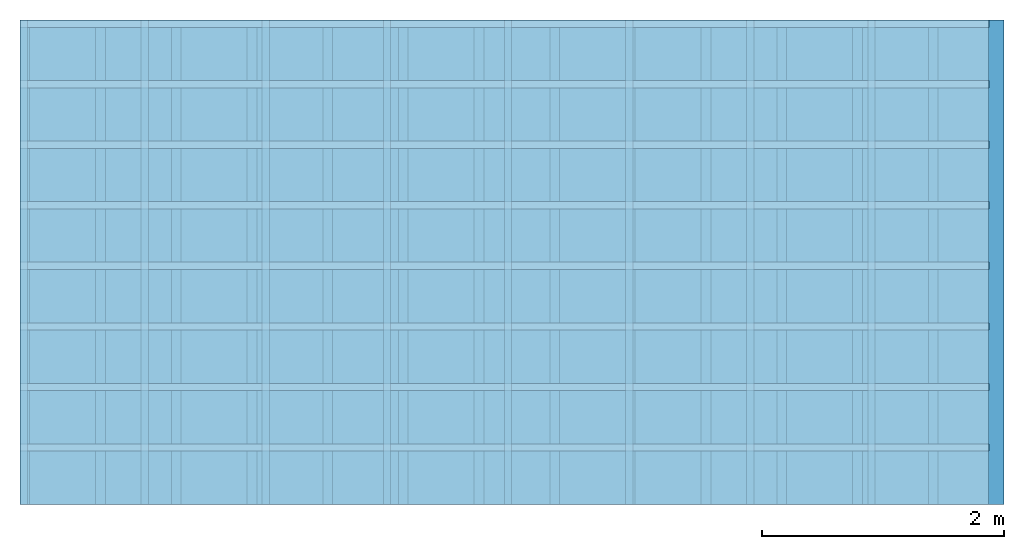
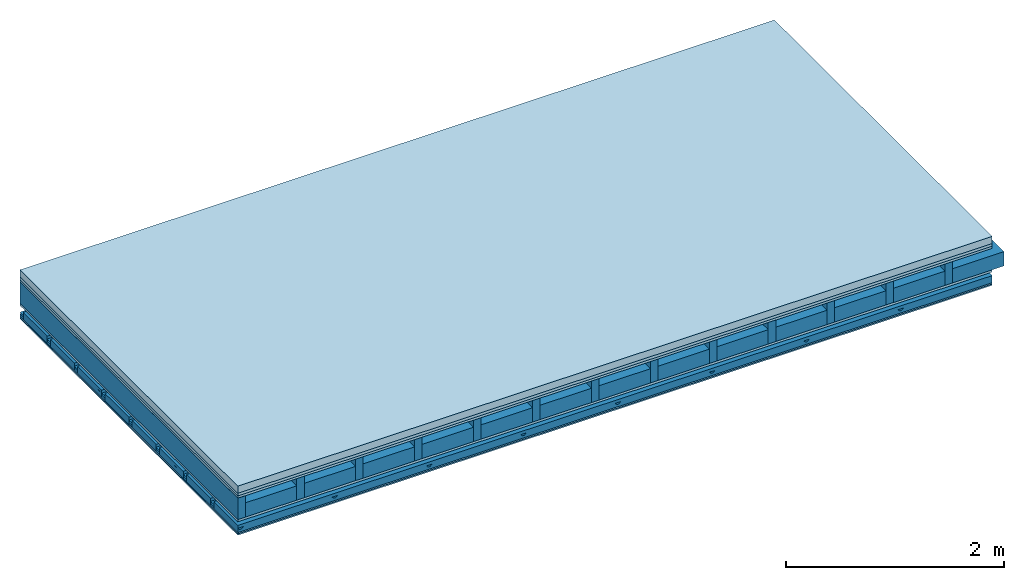
# One storey: 6 plates, 5 members, 1 element without a shape of its own.
"""IFC4 building model written with IfcOpenShell, lengths in metres."""

import ifcopenshell
import ifcopenshell.guid

model = None  # the IFC model being written
_history = None  # IfcOwnerHistory: only IFC2X3 demands one
_inside = {}  # id of a spatial element -> (the spatial element, [elements in it])
_under = {}  # id of a project, library or spatial element -> (it, [spatial elements below it])
_declared = {}  # id of a project -> (the project, [libraries it declares])
_typed = {}  # id of a type object -> (the type object, [elements of that type])
_made_of = {}  # id of a material, layer set ... -> (it, [elements and type objects made of it])


def new_model(schema):
    """Start an empty IFC model of exactly this schema.

    Asked for "IFC4X3", IfcOpenShell would pick the latest addendum, in which some entities
    have other attributes; the version numbers below select the first issue.
    IFC2X3 requires an IfcOwnerHistory on every rooted entity: one is made here for all.
    """
    global model, _history
    if schema == "IFC4X3":
        model = ifcopenshell.file(schema_version=(4, 3, 0, 0))
    else:
        model = ifcopenshell.file(schema=schema)
    _inside.clear()
    _under.clear()
    _declared.clear()
    _typed.clear()
    _made_of.clear()
    _history = None
    if model.schema == "IFC2X3":
        org = make("IfcOrganization", Name="unknown")
        user = make(
            "IfcPersonAndOrganization",
            ThePerson=make("IfcPerson", FamilyName="unknown"),
            TheOrganization=org,
        )
        app = make(
            "IfcApplication",
            ApplicationDeveloper=org,
            Version="unknown",
            ApplicationFullName="unknown",
            ApplicationIdentifier="unknown",
        )
        _history = make(
            "IfcOwnerHistory",
            OwningUser=user,
            OwningApplication=app,
            ChangeAction="ADDED",
            CreationDate=0,
        )
    return model


def make(cls, **values):
    """One entity of the class cls with the attributes given. An attribute that is None is left unset."""
    return model.create_entity(
        cls, **{name: value for name, value in values.items() if value is not None}
    )


def rooted(cls, **values):
    """An entity with a GlobalId (a new one), such as an element, a storey or a relation."""
    return make(cls, GlobalId=ifcopenshell.guid.new(), OwnerHistory=_history, **values)


def si_unit(unit_type, name, prefix=None):
    """IfcSIUnit, for example si_unit("LENGTHUNIT", "METRE", prefix="MILLI")."""
    return make("IfcSIUnit", UnitType=unit_type, Prefix=prefix, Name=name)


def derived_unit(unit_type, elements):
    """IfcDerivedUnit: a product of units, each with its exponent."""
    return make(
        "IfcDerivedUnit",
        Elements=[
            make("IfcDerivedUnitElement", Unit=unit, Exponent=power)
            for unit, power in elements
        ],
        UnitType=unit_type,
    )


def assignment(units):
    """IfcUnitAssignment: the units of a project."""
    return None if units is None else make("IfcUnitAssignment", Units=units)


def point(xyz):
    """IfcCartesianPoint."""
    return None if xyz is None else make("IfcCartesianPoint", Coordinates=xyz)


def direction(xyz):
    """IfcDirection."""
    return None if xyz is None else make("IfcDirection", DirectionRatios=xyz)


def frame(location, z_axis=None, x_axis=None):
    """IfcAxis2Placement3D, a coordinate frame: its origin and axes. An axis left out is left unset."""
    return make(
        "IfcAxis2Placement3D",
        Location=point(location),
        Axis=direction(z_axis),
        RefDirection=direction(x_axis),
    )


def frame_2d(location, x_axis=None):
    """IfcAxis2Placement2D, a coordinate frame in the plane: its origin and x axis."""
    return make(
        "IfcAxis2Placement2D", Location=point(location), RefDirection=direction(x_axis)
    )


def origin():
    """The frame at (0, 0, 0) with its axes left unset."""
    return frame((0.0, 0.0, 0.0))


def origin_with_axes():
    """The frame at (0, 0, 0) with the z axis (0, 0, 1) and the x axis (1, 0, 0) written out."""
    return frame((0.0, 0.0, 0.0), z_axis=(0.0, 0.0, 1.0), x_axis=(1.0, 0.0, 0.0))


def place(relative_to, where):
    """IfcLocalPlacement: puts the frame where relative to a parent placement (None: the world)."""
    return make(
        "IfcLocalPlacement", PlacementRelTo=relative_to, RelativePlacement=where
    )


def context(
    kind, dimensions, precision=None, world=None, true_north=None, identifier=None
):
    """IfcGeometricRepresentationContext, for example the 3D "Model" context."""
    return make(
        "IfcGeometricRepresentationContext",
        ContextIdentifier=identifier,
        ContextType=kind,
        CoordinateSpaceDimension=dimensions,
        Precision=precision,
        WorldCoordinateSystem=world,
        TrueNorth=true_north,
    )


def project(units=None, contexts=None):
    """IfcProject with its units and contexts."""
    return rooted(
        "IfcProject",
        Name="project",
        RepresentationContexts=contexts,
        UnitsInContext=assignment(units),
    )


def spatial(cls, under=None, at=None, **own):
    """A site, building, storey or space (cls), placed at a placement, below another one or the project."""
    s = rooted(cls, ObjectPlacement=at, **own)
    if under is not None:
        _under.setdefault(under.id(), (under, []))[1].append(s)
    return s


def polyline(points):
    """IfcPolyline through the points."""
    return make("IfcPolyline", Points=[point(p) for p in points])


def profile(cls, at=None, kind="AREA", **sizes):
    """A parametric profile (cls). Its sizes go by their IFC names, for example OverallWidth=200.0."""
    return make(cls, ProfileType=kind, Position=at, **sizes)


def rectangle(**sizes):
    """IfcRectangleProfileDef."""
    return profile("IfcRectangleProfileDef", **sizes)


def outline(outer, holes=None, kind="AREA"):
    """IfcArbitraryClosedProfileDef: a profile drawn as a closed curve; with holes, ...WithVoids."""
    if holes is None:
        return make("IfcArbitraryClosedProfileDef", ProfileType=kind, OuterCurve=outer)
    return make(
        "IfcArbitraryProfileDefWithVoids",
        ProfileType=kind,
        OuterCurve=outer,
        InnerCurves=holes,
    )


def extrude(swept, where, along, depth):
    """IfcExtrudedAreaSolid: the profile swept, set in the frame where, extruded along a direction by depth."""
    return make(
        "IfcExtrudedAreaSolid",
        SweptArea=swept,
        Position=where,
        ExtrudedDirection=direction(along),
        Depth=depth,
    )


def shape(context_of_items, identifier, shape_type, items):
    """IfcShapeRepresentation: the items that make up one representation, for example the "Body"."""
    return make(
        "IfcShapeRepresentation",
        ContextOfItems=context_of_items,
        RepresentationIdentifier=identifier,
        RepresentationType=shape_type,
        Items=items,
    )


def material(Name=None, Category=None):
    """IfcMaterial."""
    return make("IfcMaterial", Name=Name, Category=Category)


def layer(
    of_material, thickness, ventilated=None, Name=None, Category=None, Priority=None
):
    """IfcMaterialLayer: one layer of a wall or slab, of a material (None: an air gap)."""
    return make(
        "IfcMaterialLayer",
        Material=of_material,
        LayerThickness=thickness,
        IsVentilated=ventilated,
        Name=Name,
        Category=Category,
        Priority=Priority,
    )


def layer_set(layers, Name=None):
    """IfcMaterialLayerSet."""
    return make("IfcMaterialLayerSet", MaterialLayers=layers, LayerSetName=Name)


def made_of(thing, what):
    """Note that an element or type object is made of a material, layer set ...; save() writes the relation."""
    if what is not None:
        _made_of.setdefault(what.id(), (what, []))[1].append(thing)
    return thing


def type_object(cls, material=None, **own):
    """A type object (cls), such as IfcWallType, which elements share."""
    return made_of(rooted(cls, **own), material)


def element(
    cls,
    number,
    at=None,
    inside=None,
    cuts=None,
    type_object=None,
    material=None,
    context=None,
    identifier="Body",
    shape_type=None,
    held_by="IfcProductDefinitionShape",
    body=None,
    shapes=None,
    **own,
):
    """One element of the class cls, such as IfcWall. Its Tag is "e" and its number.

    at: its placement. inside: the storey or other place that contains it. cuts: it is an
    opening in that element (IfcRelVoidsElement). A single representation is given by context,
    identifier, shape_type and body (its items); several are given by shapes. held_by: the class
    of the entity that holds the representations. save() writes the other relations.
    """
    e = rooted(cls, Tag="e%d" % number, ObjectPlacement=at, **own)
    if body is not None:
        shapes = [shape(context, identifier, shape_type, body)]
    if shapes is not None:
        e.Representation = make(held_by, Representations=shapes)
    if inside is not None:
        _inside.setdefault(inside.id(), (inside, []))[1].append(e)
    if cuts is not None:
        rooted(
            "IfcRelVoidsElement", RelatingBuildingElement=cuts, RelatedOpeningElement=e
        )
    if type_object is not None:
        _typed.setdefault(type_object.id(), (type_object, []))[1].append(e)
    return made_of(e, material)


def aggregate(whole, parts):
    """IfcRelAggregates: a whole, such as a stair, and the parts it consists of."""
    return rooted("IfcRelAggregates", RelatingObject=whole, RelatedObjects=parts)


def save(model, path):
    """Write the relations noted so far, then the file.

    IfcRelAggregates (storeys below a building ...), IfcRelContainedInSpatialStructure (elements
    in a storey), IfcRelDefinesByType, IfcRelAssociatesMaterial and IfcRelDeclares: one each for
    every whole, place, type object, material and project.
    """
    for whole, parts in _under.values():
        aggregate(whole, parts)
    for where, things in _inside.values():
        rooted(
            "IfcRelContainedInSpatialStructure",
            RelatedElements=things,
            RelatingStructure=where,
        )
    for kind, things in _typed.values():
        rooted("IfcRelDefinesByType", RelatedObjects=things, RelatingType=kind)
    for what, things in _made_of.values():
        rooted("IfcRelAssociatesMaterial", RelatedObjects=things, RelatingMaterial=what)
    for by, libraries in _declared.values():
        rooted("IfcRelDeclares", RelatingContext=by, RelatedDefinitions=libraries)
    model.write(path)


model = new_model("IFC4")

# Units and contexts
plan_context = context("Plan", 3, precision=1e-05, world=origin(), true_north=direction((0.0, 1.0)))
model_context = context("Model", 3, precision=1e-05, world=origin(), true_north=direction((0.0, 1.0)))
ifc_project = project(units=[si_unit("LENGTHUNIT", "METRE"), derived_unit("SOUNDPRESSUREUNIT", [(si_unit("PRESSUREUNIT", "PASCAL", prefix="MICRO"), 0)]), si_unit("ENERGYUNIT", "JOULE", prefix="MEGA"), si_unit("MASSUNIT", "GRAM", prefix="KILO"), derived_unit("THERMALTRANSMITTANCEUNIT", [(si_unit("POWERUNIT", "WATT"), 1), (si_unit("AREAUNIT", "SQUARE_METRE"), -1), (si_unit("THERMODYNAMICTEMPERATUREUNIT", "KELVIN"), -1)]), derived_unit("AREADENSITYUNIT", [(si_unit("MASSUNIT", "GRAM", prefix="KILO"), 1), (si_unit("AREAUNIT", "SQUARE_METRE"), -1)]), derived_unit("USERDEFINED", [(si_unit("ENERGYUNIT", "JOULE", prefix="MEGA"), 1), (si_unit("AREAUNIT", "SQUARE_METRE"), -1)])], contexts=[plan_context, model_context])

# Site, building, storey
site = spatial("IfcSite", under=ifc_project)
building_placement = place(None, origin())
building = spatial("IfcBuilding", under=site, at=building_placement)
storey_placement = place(building_placement, origin())
storey = spatial("IfcBuildingStorey", under=building, at=storey_placement)

# Slab, members, plates
ifc_material_1 = material(Name="Cement screed", Category="04.006")
ifc_layer_1 = layer(ifc_material_1, 0.08, Name="On-material")
ifc_material_2 = material()
ifc_layer_2 = layer(ifc_material_2, 0.03, Name="Impact sound insulation")
ifc_material_3 = material(Category="07.001")
ifc_layer_3 = layer(ifc_material_3, 0.025, Name="Sub-floor")
ifc_material_4 = material(Name="Rigid, of the art")
ifc_layer_4 = layer(ifc_material_4, 0.0, Name="Bond")
ifc_layer_5 = layer(None, 0.24, Name="Supporting structure")
ifc_layer_6 = layer(ifc_material_4, 0.0, Name="Bond")
ifc_layer_7 = layer(ifc_material_3, 0.025, Name="Lower layer 1")
ifc_layer_8 = layer(None, 0.093, Name="Coupling")
ifc_layer_9 = layer(None, 0.027, Name="Battens / profiles")
ifc_material_5 = material(Name="Plasterboard type A", Category="03.008")
ifc_layer_10 = layer(ifc_material_5, 0.015, Name="Ceiling covering 1st layer")
ifc_layer_11 = layer(ifc_material_5, 0.015, Name="Ceiling covering layer 2")
ifc_material_6 = material(Name="joints", Category="04.017")
ifc_layer_12 = layer(ifc_material_6, 0.0, Name="Surface / treatment")
ifc_layer_set = layer_set([ifc_layer_1, ifc_layer_2, ifc_layer_3, ifc_layer_4, ifc_layer_5, ifc_layer_6, ifc_layer_7, ifc_layer_8, ifc_layer_9, ifc_layer_10, ifc_layer_11, ifc_layer_12])
slab_type = type_object("IfcSlabType", Name="A0418", PredefinedType="NOTDEFINED", material=ifc_layer_set)
slab_placement = place(None, frame((0.0, 0.0, 0.0), z_axis=(0.0, 0.0, -1.0), x_axis=(1.0, 0.0, 0.0)))
slab = element("IfcSlab", 1, at=slab_placement, inside=storey, type_object=slab_type, material=ifc_layer_set, Name="Slab #1")
ifc_material_7 = material()
member_1_placement = place(slab_placement, origin())
member_1 = element("IfcMember", 2, at=member_1_placement, material=ifc_material_7, Name="Supporting structure", context=plan_context, shape_type="SweptSolid", body=[
    extrude(rectangle(XDim=0.08, YDim=0.24, at=frame_2d((0.04, 0.12), x_axis=(1.0, 0.0))), frame((0.0, 4.0, 0.135), z_axis=(0.0, -1.0, 0.0), x_axis=(1.0, 0.0, 0.0)), (0.0, 0.0, 1.0), 4.0),
    extrude(rectangle(XDim=0.08, YDim=0.24, at=frame_2d((0.04, 0.12), x_axis=(1.0, 0.0))), frame((0.625, 4.0, 0.135), z_axis=(0.0, -1.0, 0.0), x_axis=(1.0, 0.0, 0.0)), (0.0, 0.0, 1.0), 4.0),
    extrude(rectangle(XDim=0.08, YDim=0.24, at=frame_2d((0.04, 0.12), x_axis=(1.0, 0.0))), frame((1.25, 4.0, 0.135), z_axis=(0.0, -1.0, 0.0), x_axis=(1.0, 0.0, 0.0)), (0.0, 0.0, 1.0), 4.0),
    extrude(rectangle(XDim=0.08, YDim=0.24, at=frame_2d((0.04, 0.12), x_axis=(1.0, 0.0))), frame((1.875, 4.0, 0.135), z_axis=(0.0, -1.0, 0.0), x_axis=(1.0, 0.0, 0.0)), (0.0, 0.0, 1.0), 4.0),
    extrude(rectangle(XDim=0.08, YDim=0.24, at=frame_2d((0.04, 0.12), x_axis=(1.0, 0.0))), frame((2.5, 4.0, 0.135), z_axis=(0.0, -1.0, 0.0), x_axis=(1.0, 0.0, 0.0)), (0.0, 0.0, 1.0), 4.0),
    extrude(rectangle(XDim=0.08, YDim=0.24, at=frame_2d((0.04, 0.12), x_axis=(1.0, 0.0))), frame((3.125, 4.0, 0.135), z_axis=(0.0, -1.0, 0.0), x_axis=(1.0, 0.0, 0.0)), (0.0, 0.0, 1.0), 4.0),
    extrude(rectangle(XDim=0.08, YDim=0.24, at=frame_2d((0.04, 0.12), x_axis=(1.0, 0.0))), frame((3.75, 4.0, 0.135), z_axis=(0.0, -1.0, 0.0), x_axis=(1.0, 0.0, 0.0)), (0.0, 0.0, 1.0), 4.0),
    extrude(rectangle(XDim=0.08, YDim=0.24, at=frame_2d((0.04, 0.12), x_axis=(1.0, 0.0))), frame((4.375, 4.0, 0.135), z_axis=(0.0, -1.0, 0.0), x_axis=(1.0, 0.0, 0.0)), (0.0, 0.0, 1.0), 4.0),
    extrude(rectangle(XDim=0.08, YDim=0.24, at=frame_2d((0.04, 0.12), x_axis=(1.0, 0.0))), frame((5.0, 4.0, 0.135), z_axis=(0.0, -1.0, 0.0), x_axis=(1.0, 0.0, 0.0)), (0.0, 0.0, 1.0), 4.0),
    extrude(rectangle(XDim=0.08, YDim=0.24, at=frame_2d((0.04, 0.12), x_axis=(1.0, 0.0))), frame((5.625, 4.0, 0.135), z_axis=(0.0, -1.0, 0.0), x_axis=(1.0, 0.0, 0.0)), (0.0, 0.0, 1.0), 4.0),
    extrude(rectangle(XDim=0.08, YDim=0.24, at=frame_2d((0.04, 0.12), x_axis=(1.0, 0.0))), frame((6.25, 4.0, 0.135), z_axis=(0.0, -1.0, 0.0), x_axis=(1.0, 0.0, 0.0)), (0.0, 0.0, 1.0), 4.0),
    extrude(rectangle(XDim=0.08, YDim=0.24, at=frame_2d((0.04, 0.12), x_axis=(1.0, 0.0))), frame((6.875, 4.0, 0.135), z_axis=(0.0, -1.0, 0.0), x_axis=(1.0, 0.0, 0.0)), (0.0, 0.0, 1.0), 4.0),
    extrude(rectangle(XDim=0.08, YDim=0.24, at=frame_2d((0.04, 0.12), x_axis=(1.0, 0.0))), frame((7.5, 4.0, 0.135), z_axis=(0.0, -1.0, 0.0), x_axis=(1.0, 0.0, 0.0)), (0.0, 0.0, 1.0), 4.0),
])
ifc_material_8 = material()
member_2_placement = place(slab_placement, origin())
member_2 = element("IfcMember", 3, at=member_2_placement, material=ifc_material_8, Name="Cavity", context=plan_context, shape_type="SweptSolid", body=[
    extrude(rectangle(XDim=0.545, YDim=0.16, at=frame_2d((0.2725, 0.08), x_axis=(1.0, 0.0))), frame((0.08, 4.0, 0.215), z_axis=(0.0, -1.0, 0.0), x_axis=(1.0, 0.0, 0.0)), (0.0, 0.0, 1.0), 4.0),
    extrude(rectangle(XDim=0.545, YDim=0.16, at=frame_2d((0.2725, 0.08), x_axis=(1.0, 0.0))), frame((0.705, 4.0, 0.215), z_axis=(0.0, -1.0, 0.0), x_axis=(1.0, 0.0, 0.0)), (0.0, 0.0, 1.0), 4.0),
    extrude(rectangle(XDim=0.545, YDim=0.16, at=frame_2d((0.2725, 0.08), x_axis=(1.0, 0.0))), frame((1.33, 4.0, 0.215), z_axis=(0.0, -1.0, 0.0), x_axis=(1.0, 0.0, 0.0)), (0.0, 0.0, 1.0), 4.0),
    extrude(rectangle(XDim=0.545, YDim=0.16, at=frame_2d((0.2725, 0.08), x_axis=(1.0, 0.0))), frame((1.955, 4.0, 0.215), z_axis=(0.0, -1.0, 0.0), x_axis=(1.0, 0.0, 0.0)), (0.0, 0.0, 1.0), 4.0),
    extrude(rectangle(XDim=0.545, YDim=0.16, at=frame_2d((0.2725, 0.08), x_axis=(1.0, 0.0))), frame((2.58, 4.0, 0.215), z_axis=(0.0, -1.0, 0.0), x_axis=(1.0, 0.0, 0.0)), (0.0, 0.0, 1.0), 4.0),
    extrude(rectangle(XDim=0.545, YDim=0.16, at=frame_2d((0.2725, 0.08), x_axis=(1.0, 0.0))), frame((3.205, 4.0, 0.215), z_axis=(0.0, -1.0, 0.0), x_axis=(1.0, 0.0, 0.0)), (0.0, 0.0, 1.0), 4.0),
    extrude(rectangle(XDim=0.545, YDim=0.16, at=frame_2d((0.2725, 0.08), x_axis=(1.0, 0.0))), frame((3.83, 4.0, 0.215), z_axis=(0.0, -1.0, 0.0), x_axis=(1.0, 0.0, 0.0)), (0.0, 0.0, 1.0), 4.0),
    extrude(rectangle(XDim=0.545, YDim=0.16, at=frame_2d((0.2725, 0.08), x_axis=(1.0, 0.0))), frame((4.455, 4.0, 0.215), z_axis=(0.0, -1.0, 0.0), x_axis=(1.0, 0.0, 0.0)), (0.0, 0.0, 1.0), 4.0),
    extrude(rectangle(XDim=0.545, YDim=0.16, at=frame_2d((0.2725, 0.08), x_axis=(1.0, 0.0))), frame((5.08, 4.0, 0.215), z_axis=(0.0, -1.0, 0.0), x_axis=(1.0, 0.0, 0.0)), (0.0, 0.0, 1.0), 4.0),
    extrude(rectangle(XDim=0.545, YDim=0.16, at=frame_2d((0.2725, 0.08), x_axis=(1.0, 0.0))), frame((5.705, 4.0, 0.215), z_axis=(0.0, -1.0, 0.0), x_axis=(1.0, 0.0, 0.0)), (0.0, 0.0, 1.0), 4.0),
    extrude(rectangle(XDim=0.545, YDim=0.16, at=frame_2d((0.2725, 0.08), x_axis=(1.0, 0.0))), frame((6.33, 4.0, 0.215), z_axis=(0.0, -1.0, 0.0), x_axis=(1.0, 0.0, 0.0)), (0.0, 0.0, 1.0), 4.0),
    extrude(rectangle(XDim=0.545, YDim=0.16, at=frame_2d((0.2725, 0.08), x_axis=(1.0, 0.0))), frame((6.955, 4.0, 0.215), z_axis=(0.0, -1.0, 0.0), x_axis=(1.0, 0.0, 0.0)), (0.0, 0.0, 1.0), 4.0),
    extrude(rectangle(XDim=0.545, YDim=0.16, at=frame_2d((0.2725, 0.08), x_axis=(1.0, 0.0))), frame((7.58, 4.0, 0.215), z_axis=(0.0, -1.0, 0.0), x_axis=(1.0, 0.0, 0.0)), (0.0, 0.0, 1.0), 4.0),
])
ifc_material_9 = material()
member_3_placement = place(slab_placement, origin())
member_3 = element("IfcMember", 4, at=member_3_placement, material=ifc_material_9, Name="Coupling", context=plan_context, shape_type="SweptSolid", body=[
    extrude(outline(polyline([(0.0, 0.0), (0.06, 0.0), (0.04, 0.02), (0.02, 0.02), (0.0, 0.0)])), frame((0.0, 4.0, 0.473), z_axis=(0.0, -1.0, 0.0), x_axis=(1.0, 0.0, 0.0)), (0.0, 0.0, 1.0), 4.0),
    extrude(outline(polyline([(0.0, 0.0), (0.06, 0.0), (0.04, 0.02), (0.02, 0.02), (0.0, 0.0)])), frame((1.0, 4.0, 0.473), z_axis=(0.0, -1.0, 0.0), x_axis=(1.0, 0.0, 0.0)), (0.0, 0.0, 1.0), 4.0),
    extrude(outline(polyline([(0.0, 0.0), (0.06, 0.0), (0.04, 0.02), (0.02, 0.02), (0.0, 0.0)])), frame((2.0, 4.0, 0.473), z_axis=(0.0, -1.0, 0.0), x_axis=(1.0, 0.0, 0.0)), (0.0, 0.0, 1.0), 4.0),
    extrude(outline(polyline([(0.0, 0.0), (0.06, 0.0), (0.04, 0.02), (0.02, 0.02), (0.0, 0.0)])), frame((3.0, 4.0, 0.473), z_axis=(0.0, -1.0, 0.0), x_axis=(1.0, 0.0, 0.0)), (0.0, 0.0, 1.0), 4.0),
    extrude(outline(polyline([(0.0, 0.0), (0.06, 0.0), (0.04, 0.02), (0.02, 0.02), (0.0, 0.0)])), frame((4.0, 4.0, 0.473), z_axis=(0.0, -1.0, 0.0), x_axis=(1.0, 0.0, 0.0)), (0.0, 0.0, 1.0), 4.0),
    extrude(outline(polyline([(0.0, 0.0), (0.06, 0.0), (0.04, 0.02), (0.02, 0.02), (0.0, 0.0)])), frame((5.0, 4.0, 0.473), z_axis=(0.0, -1.0, 0.0), x_axis=(1.0, 0.0, 0.0)), (0.0, 0.0, 1.0), 4.0),
    extrude(outline(polyline([(0.0, 0.0), (0.06, 0.0), (0.04, 0.02), (0.02, 0.02), (0.0, 0.0)])), frame((6.0, 4.0, 0.473), z_axis=(0.0, -1.0, 0.0), x_axis=(1.0, 0.0, 0.0)), (0.0, 0.0, 1.0), 4.0),
    extrude(outline(polyline([(0.0, 0.0), (0.06, 0.0), (0.04, 0.02), (0.02, 0.02), (0.0, 0.0)])), frame((7.0, 4.0, 0.473), z_axis=(0.0, -1.0, 0.0), x_axis=(1.0, 0.0, 0.0)), (0.0, 0.0, 1.0), 4.0),
])
ifc_material_10 = material()
member_4_placement = place(slab_placement, origin())
member_4 = element("IfcMember", 5, at=member_4_placement, material=ifc_material_10, Name="Battens / profiles", context=plan_context, shape_type="SweptSolid", body=[
    extrude(rectangle(XDim=0.06, YDim=0.027, at=frame_2d((0.03, 0.0135), x_axis=(1.0, 0.0))), frame((0.0, 0.0, 0.493), z_axis=(1.0, 0.0, 0.0), x_axis=(0.0, 1.0, 0.0)), (0.0, 0.0, 1.0), 8.0),
    extrude(rectangle(XDim=0.06, YDim=0.027, at=frame_2d((0.03, 0.0135), x_axis=(1.0, 0.0))), frame((0.0, 0.5, 0.493), z_axis=(1.0, 0.0, 0.0), x_axis=(0.0, 1.0, 0.0)), (0.0, 0.0, 1.0), 8.0),
    extrude(rectangle(XDim=0.06, YDim=0.027, at=frame_2d((0.03, 0.0135), x_axis=(1.0, 0.0))), frame((0.0, 1.0, 0.493), z_axis=(1.0, 0.0, 0.0), x_axis=(0.0, 1.0, 0.0)), (0.0, 0.0, 1.0), 8.0),
    extrude(rectangle(XDim=0.06, YDim=0.027, at=frame_2d((0.03, 0.0135), x_axis=(1.0, 0.0))), frame((0.0, 1.5, 0.493), z_axis=(1.0, 0.0, 0.0), x_axis=(0.0, 1.0, 0.0)), (0.0, 0.0, 1.0), 8.0),
    extrude(rectangle(XDim=0.06, YDim=0.027, at=frame_2d((0.03, 0.0135), x_axis=(1.0, 0.0))), frame((0.0, 2.0, 0.493), z_axis=(1.0, 0.0, 0.0), x_axis=(0.0, 1.0, 0.0)), (0.0, 0.0, 1.0), 8.0),
    extrude(rectangle(XDim=0.06, YDim=0.027, at=frame_2d((0.03, 0.0135), x_axis=(1.0, 0.0))), frame((0.0, 2.5, 0.493), z_axis=(1.0, 0.0, 0.0), x_axis=(0.0, 1.0, 0.0)), (0.0, 0.0, 1.0), 8.0),
    extrude(rectangle(XDim=0.06, YDim=0.027, at=frame_2d((0.03, 0.0135), x_axis=(1.0, 0.0))), frame((0.0, 3.0, 0.493), z_axis=(1.0, 0.0, 0.0), x_axis=(0.0, 1.0, 0.0)), (0.0, 0.0, 1.0), 8.0),
    extrude(rectangle(XDim=0.06, YDim=0.027, at=frame_2d((0.03, 0.0135), x_axis=(1.0, 0.0))), frame((0.0, 3.5, 0.493), z_axis=(1.0, 0.0, 0.0), x_axis=(0.0, 1.0, 0.0)), (0.0, 0.0, 1.0), 8.0),
])
member_5_placement = place(slab_placement, origin())
member_5 = element("IfcMember", 6, at=member_5_placement, material=ifc_material_8, Name="Cavity", context=plan_context, shape_type="SweptSolid", body=[
    extrude(rectangle(XDim=0.44, YDim=0.08, at=frame_2d((0.22, 0.04), x_axis=(1.0, 0.0))), frame((0.0, 0.06, 0.44), z_axis=(1.0, 0.0, 0.0), x_axis=(0.0, 1.0, 0.0)), (0.0, 0.0, 1.0), 8.0),
    extrude(rectangle(XDim=0.44, YDim=0.08, at=frame_2d((0.22, 0.04), x_axis=(1.0, 0.0))), frame((0.0, 0.56, 0.44), z_axis=(1.0, 0.0, 0.0), x_axis=(0.0, 1.0, 0.0)), (0.0, 0.0, 1.0), 8.0),
    extrude(rectangle(XDim=0.44, YDim=0.08, at=frame_2d((0.22, 0.04), x_axis=(1.0, 0.0))), frame((0.0, 1.06, 0.44), z_axis=(1.0, 0.0, 0.0), x_axis=(0.0, 1.0, 0.0)), (0.0, 0.0, 1.0), 8.0),
    extrude(rectangle(XDim=0.44, YDim=0.08, at=frame_2d((0.22, 0.04), x_axis=(1.0, 0.0))), frame((0.0, 1.56, 0.44), z_axis=(1.0, 0.0, 0.0), x_axis=(0.0, 1.0, 0.0)), (0.0, 0.0, 1.0), 8.0),
    extrude(rectangle(XDim=0.44, YDim=0.08, at=frame_2d((0.22, 0.04), x_axis=(1.0, 0.0))), frame((0.0, 2.06, 0.44), z_axis=(1.0, 0.0, 0.0), x_axis=(0.0, 1.0, 0.0)), (0.0, 0.0, 1.0), 8.0),
    extrude(rectangle(XDim=0.44, YDim=0.08, at=frame_2d((0.22, 0.04), x_axis=(1.0, 0.0))), frame((0.0, 2.56, 0.44), z_axis=(1.0, 0.0, 0.0), x_axis=(0.0, 1.0, 0.0)), (0.0, 0.0, 1.0), 8.0),
    extrude(rectangle(XDim=0.44, YDim=0.08, at=frame_2d((0.22, 0.04), x_axis=(1.0, 0.0))), frame((0.0, 3.06, 0.44), z_axis=(1.0, 0.0, 0.0), x_axis=(0.0, 1.0, 0.0)), (0.0, 0.0, 1.0), 8.0),
    extrude(rectangle(XDim=0.44, YDim=0.08, at=frame_2d((0.22, 0.04), x_axis=(1.0, 0.0))), frame((0.0, 3.56, 0.44), z_axis=(1.0, 0.0, 0.0), x_axis=(0.0, 1.0, 0.0)), (0.0, 0.0, 1.0), 8.0),
])
plate_1_placement = place(slab_placement, origin())
plate_1 = element("IfcPlate", 7, at=plate_1_placement, material=ifc_material_1, Name="On-material", context=plan_context, shape_type="SweptSolid", body=[
    extrude(rectangle(XDim=8.0, YDim=4.0, at=frame_2d((4.0, 2.0), x_axis=(1.0, 0.0))), origin_with_axes(), (0.0, 0.0, 1.0), 0.08),
])
plate_2_placement = place(slab_placement, origin())
plate_2 = element("IfcPlate", 8, at=plate_2_placement, material=ifc_material_2, Name="Impact sound insulation", context=plan_context, shape_type="SweptSolid", body=[
    extrude(rectangle(XDim=8.0, YDim=4.0, at=frame_2d((4.0, 2.0), x_axis=(1.0, 0.0))), frame((0.0, 0.0, 0.08), z_axis=(0.0, 0.0, 1.0), x_axis=(1.0, 0.0, 0.0)), (0.0, 0.0, 1.0), 0.03),
])
plate_3_placement = place(slab_placement, origin())
plate_3 = element("IfcPlate", 9, at=plate_3_placement, material=ifc_material_3, Name="Sub-floor", context=plan_context, shape_type="SweptSolid", body=[
    extrude(rectangle(XDim=8.0, YDim=4.0, at=frame_2d((4.0, 2.0), x_axis=(1.0, 0.0))), frame((0.0, 0.0, 0.11), z_axis=(0.0, 0.0, 1.0), x_axis=(1.0, 0.0, 0.0)), (0.0, 0.0, 1.0), 0.025),
])
plate_4_placement = place(slab_placement, origin())
plate_4 = element("IfcPlate", 10, at=plate_4_placement, material=ifc_material_3, Name="Lower layer 1", context=plan_context, shape_type="SweptSolid", body=[
    extrude(rectangle(XDim=8.0, YDim=4.0, at=frame_2d((4.0, 2.0), x_axis=(1.0, 0.0))), frame((0.0, 0.0, 0.375), z_axis=(0.0, 0.0, 1.0), x_axis=(1.0, 0.0, 0.0)), (0.0, 0.0, 1.0), 0.025),
])
plate_5_placement = place(slab_placement, origin())
plate_5 = element("IfcPlate", 11, at=plate_5_placement, material=ifc_material_5, Name="Ceiling covering 1st layer", context=plan_context, shape_type="SweptSolid", body=[
    extrude(rectangle(XDim=8.0, YDim=4.0, at=frame_2d((4.0, 2.0), x_axis=(1.0, 0.0))), frame((0.0, 0.0, 0.52), z_axis=(0.0, 0.0, 1.0), x_axis=(1.0, 0.0, 0.0)), (0.0, 0.0, 1.0), 0.015),
])
plate_6_placement = place(slab_placement, origin())
plate_6 = element("IfcPlate", 12, at=plate_6_placement, material=ifc_material_5, Name="Ceiling covering layer 2", context=plan_context, shape_type="SweptSolid", body=[
    extrude(rectangle(XDim=8.0, YDim=4.0, at=frame_2d((4.0, 2.0), x_axis=(1.0, 0.0))), frame((0.0, 0.0, 0.535), z_axis=(0.0, 0.0, 1.0), x_axis=(1.0, 0.0, 0.0)), (0.0, 0.0, 1.0), 0.015),
])
aggregate(slab, [plate_1, plate_2, plate_3, member_1, member_2, plate_4, member_3, member_4, member_5, plate_5, plate_6])

save(model, "model.ifc")
